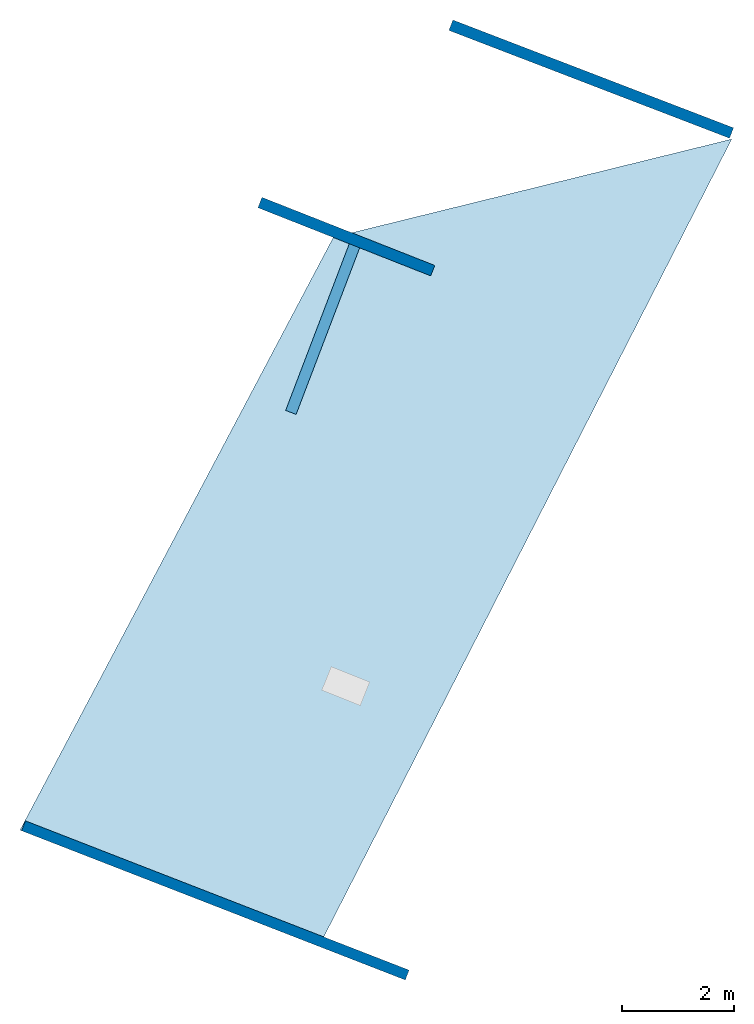
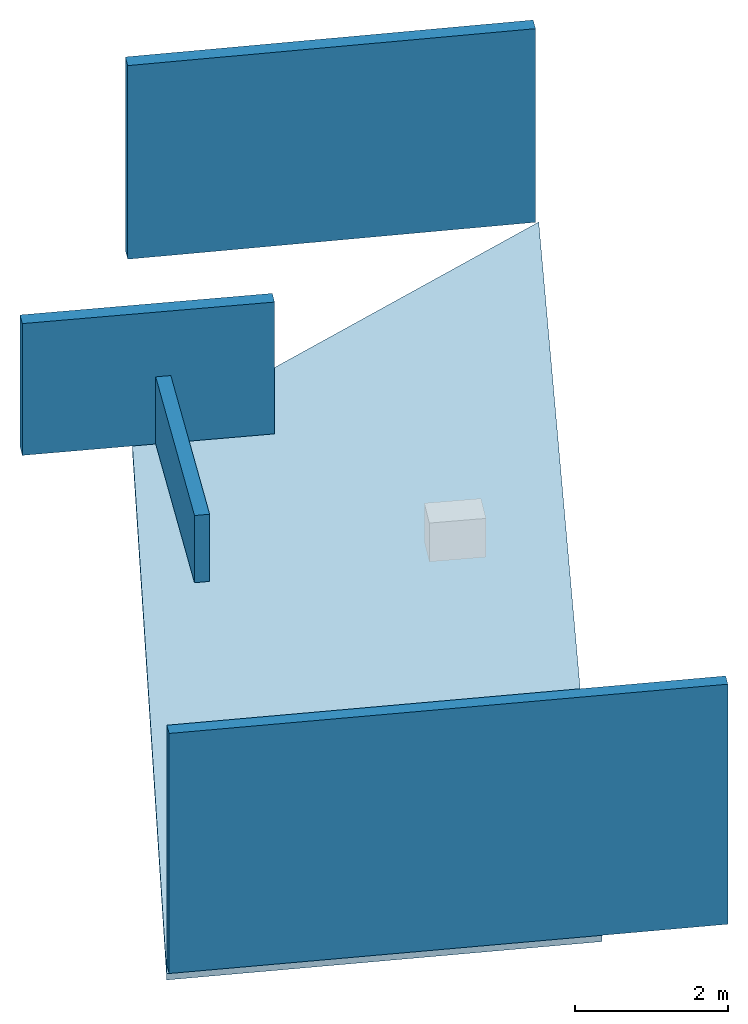
# One storey, part 1 of 2: 4 walls, 1 slab.
"""IFC2X3 building model written with IfcOpenShell, lengths in metres."""

from ifc_helpers import new_model, entity, si_unit, converted_unit, derived_unit, direction, frame, origin, place, context, subcontext, project, spatial, polyline, outline, extrude, material, layer, layer_set, layer_usage, type_object, element, save


model = new_model("IFC2X3")

# Units and contexts
model_context = context("Model", 3, precision=1e-05, world=origin(), true_north=direction((0.0, 1.0)))
body_context = subcontext(model_context, "Body", "Model", "MODEL_VIEW")
ifc_project = project(units=[si_unit("LENGTHUNIT", "METRE"), si_unit("AREAUNIT", "SQUARE_METRE"), si_unit("VOLUMEUNIT", "CUBIC_METRE"), converted_unit("PLANEANGLEUNIT", "DEGREE", entity("IfcRatioMeasure", 0.0174532925199433), si_unit("PLANEANGLEUNIT", "RADIAN"), dimensions=[0, 0, 0, 0, 0, 0, 0]), si_unit("MASSUNIT", "GRAM", prefix="KILO"), derived_unit("MASSDENSITYUNIT", [(si_unit("MASSUNIT", "GRAM", prefix="KILO"), 1), (si_unit("LENGTHUNIT", "METRE"), -3)]), derived_unit("MOMENTOFINERTIAUNIT", [(si_unit("LENGTHUNIT", "METRE"), 4)]), si_unit("TIMEUNIT", "SECOND"), si_unit("FREQUENCYUNIT", "HERTZ"), si_unit("THERMODYNAMICTEMPERATUREUNIT", "DEGREE_CELSIUS"), derived_unit("THERMALTRANSMITTANCEUNIT", [(si_unit("MASSUNIT", "GRAM", prefix="KILO"), 1), (si_unit("THERMODYNAMICTEMPERATUREUNIT", "KELVIN"), -1), (si_unit("TIMEUNIT", "SECOND"), -3)]), derived_unit("VOLUMETRICFLOWRATEUNIT", [(si_unit("LENGTHUNIT", "METRE"), 3), (si_unit("TIMEUNIT", "SECOND"), -1)]), si_unit("ELECTRICCURRENTUNIT", "AMPERE"), si_unit("ELECTRICVOLTAGEUNIT", "VOLT"), si_unit("POWERUNIT", "WATT"), si_unit("FORCEUNIT", "NEWTON", prefix="KILO"), si_unit("ILLUMINANCEUNIT", "LUX"), si_unit("LUMINOUSFLUXUNIT", "LUMEN"), si_unit("LUMINOUSINTENSITYUNIT", "CANDELA"), derived_unit("USERDEFINED", [(si_unit("MASSUNIT", "GRAM", prefix="KILO"), -1), (si_unit("LENGTHUNIT", "METRE"), -2), (si_unit("TIMEUNIT", "SECOND"), 3), (si_unit("LUMINOUSFLUXUNIT", "LUMEN"), 1)]), derived_unit("LINEARVELOCITYUNIT", [(si_unit("LENGTHUNIT", "METRE"), 1), (si_unit("TIMEUNIT", "SECOND"), -1)]), si_unit("PRESSUREUNIT", "PASCAL"), derived_unit("USERDEFINED", [(si_unit("LENGTHUNIT", "METRE"), -2), (si_unit("MASSUNIT", "GRAM", prefix="KILO"), 1), (si_unit("TIMEUNIT", "SECOND"), -2)]), derived_unit("LINEARFORCEUNIT", [(si_unit("MASSUNIT", "GRAM", prefix="KILO"), 1), (si_unit("LENGTHUNIT", "METRE"), 1), (si_unit("TIMEUNIT", "SECOND"), -2), (si_unit("LENGTHUNIT", "METRE"), -1)]), derived_unit("PLANARFORCEUNIT", [(si_unit("MASSUNIT", "GRAM", prefix="KILO"), 1), (si_unit("LENGTHUNIT", "METRE"), 1), (si_unit("TIMEUNIT", "SECOND"), -2), (si_unit("LENGTHUNIT", "METRE"), -2)])], contexts=[model_context])

# Site, building, storey
placement = place(None, origin())
site = spatial("IfcSite", under=ifc_project, at=placement, CompositionType="ELEMENT")
building = spatial("IfcBuilding", under=site, at=placement, CompositionType="ELEMENT")
storey_placement = place(placement, frame((0.0, 0.0, -79.2126846313477)))
storey = spatial("IfcBuildingStorey", under=building, at=storey_placement, Name="Level 2", CompositionType="ELEMENT", Elevation=-79.2126846313477)

# Slab
ifc_material_1 = material(Name="Floor default")
ifc_layer_1 = layer(ifc_material_1, 0.1)
ifc_layer_set_1 = layer_set([ifc_layer_1], Name="Floor : 100mm")
ifc_layer_usage_1 = layer_usage(ifc_layer_set_1, "AXIS3", "POSITIVE", 0.0)
slab_type = type_object("IfcSlabType", Name="Floor : 100mm", PredefinedType="FLOOR")
slab_placement = place(storey_placement, origin())
element("IfcSlab", 1, at=slab_placement, inside=storey, type_object=slab_type, material=ifc_layer_usage_1, Name="Floor : 100mm", ObjectType="Floor : 100mm", PredefinedType="FLOOR", context=body_context, shape_type="SweptSolid", body=[
    extrude(outline(polyline([(5.68635988235474, 11.9333200454712), (-1.12625002861023, 10.25465965271), (-1.45535004138947, 10.173939704895), (-7.07453012466431, -0.455559998750687), (-1.71511995792389, -2.54044008255005), (5.68635988235474, 11.9333200454712)])), frame((0.0, 0.0, -0.1), z_axis=(0.0, 0.0, 1.0), x_axis=(1.0, 0.0, 0.0)), (0.0, 0.0, 1.0), 0.1),
])

# Walls
ifc_material_2 = material(Name="Default wall")
ifc_layer_2 = layer(ifc_material_2, 0.2)
ifc_layer_set_2 = layer_set([ifc_layer_2], Name="wall_thickness_0.2000")
ifc_layer_usage_2 = layer_usage(ifc_layer_set_2, "AXIS2", "POSITIVE", -0.1)
wall_type_1 = type_object("IfcWallType", Name="wall_thickness_0.2000", PredefinedType="STANDARD", material=ifc_layer_set_2)
wall_1_placement = place(storey_placement, frame((0.65125748054372, 13.9755469101047, 0.0), z_axis=(0.0, 0.0, 1.0), x_axis=(0.933438096194076, -0.358738512810624, 0.0)))
element("IfcWallStandardCase", 2, at=wall_1_placement, inside=storey, type_object=wall_type_1, material=ifc_layer_usage_2, Name="Wall:0", ObjectType="Wall", context=body_context, shape_type="SweptSolid", body=[
    extrude(outline(polyline([(5.38999955865054, -0.1), (5.38999955865054, 0.1), (0.0, 0.1), (0.0, -0.1), (5.38999955865054, -0.1)])), origin(), (0.0, 0.0, 1.0), 3.08556365966797),
])
wall_2_placement = place(storey_placement, frame((-2.77283336443212, 10.796606661841, 0.0), z_axis=(0.0, 0.0, 1.0), x_axis=(0.930255641772117, -0.366912034350396, 0.0)))
element("IfcWallStandardCase", 3, at=wall_2_placement, inside=storey, type_object=wall_type_1, material=ifc_layer_usage_2, Name="Wall:2", ObjectType="Wall", context=body_context, shape_type="SweptSolid", body=[
    extrude(outline(polyline([(3.32999984250924, -0.1), (3.32999984250924, 0.1), (0.0, 0.1), (0.0, -0.1), (3.32999984250924, -0.1)])), origin(), (0.0, 0.0, 1.0), 2.10056304931641),
])
wall_3_placement = place(storey_placement, frame((-2.21781127761588, 7.03366704175507, 0.0), z_axis=(0.0, 0.0, 1.0), x_axis=(0.356525804673687, 0.934285475966409, 0.0)))
element("IfcWallStandardCase", 4, at=wall_3_placement, inside=storey, type_object=wall_type_1, material=ifc_layer_usage_2, Name="Wall:3", ObjectType="Wall", context=body_context, shape_type="SweptSolid", body=[
    extrude(outline(polyline([(3.29705535343946, -0.1), (3.29705535343946, 0.1), (0.0, 0.1), (0.0, -0.1), (3.29705535343946, -0.1)])), origin(), (0.0, 0.0, 1.0), 1.07056427001953),
])
ifc_layer_3 = layer(ifc_material_2, 0.189999997615814)
ifc_layer_set_3 = layer_set([ifc_layer_3], Name="wall_thickness_0.1900")
ifc_layer_usage_3 = layer_usage(ifc_layer_set_3, "AXIS2", "POSITIVE", -0.0949999988079071)
wall_type_2 = type_object("IfcWallType", Name="wall_thickness_0.1900", PredefinedType="STANDARD", material=ifc_layer_set_3)
wall_4_placement = place(storey_placement, frame((-7.01065202753179, -0.378471640144183, 0.0), z_axis=(0.0, 0.0, 1.0), x_axis=(0.931965404629471, -0.362547217026729, 0.0)))
element("IfcWallStandardCase", 5, at=wall_4_placement, inside=storey, type_object=wall_type_2, material=ifc_layer_usage_3, Name="Wall:4", ObjectType="Wall", context=body_context, shape_type="SweptSolid", body=[
    extrude(outline(polyline([(7.38000175576662, -0.0949999988079071), (7.38000175576662, 0.0949999988079071), (0.0, 0.0949999988079071), (0.0, -0.0949999988079071), (7.38000175576662, -0.0949999988079071)])), origin(), (0.0, 0.0, 1.0), 3.8255615234375),
])

save(model, "model.ifc")
